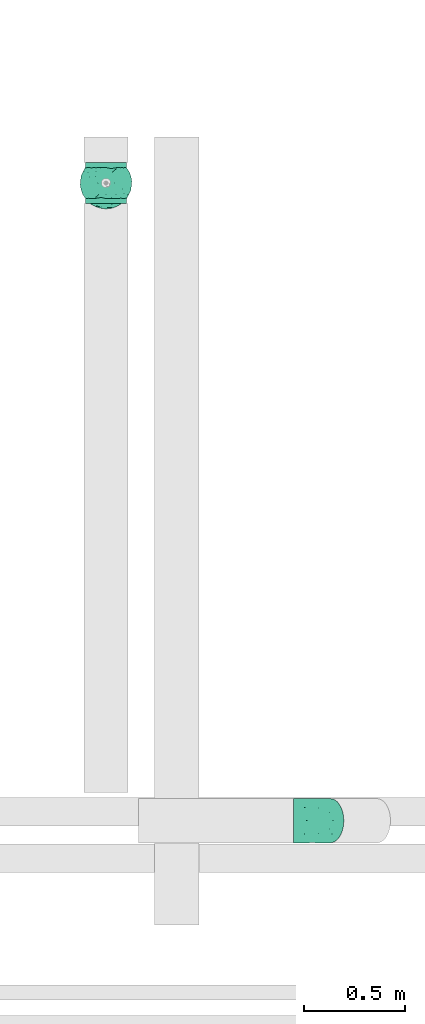
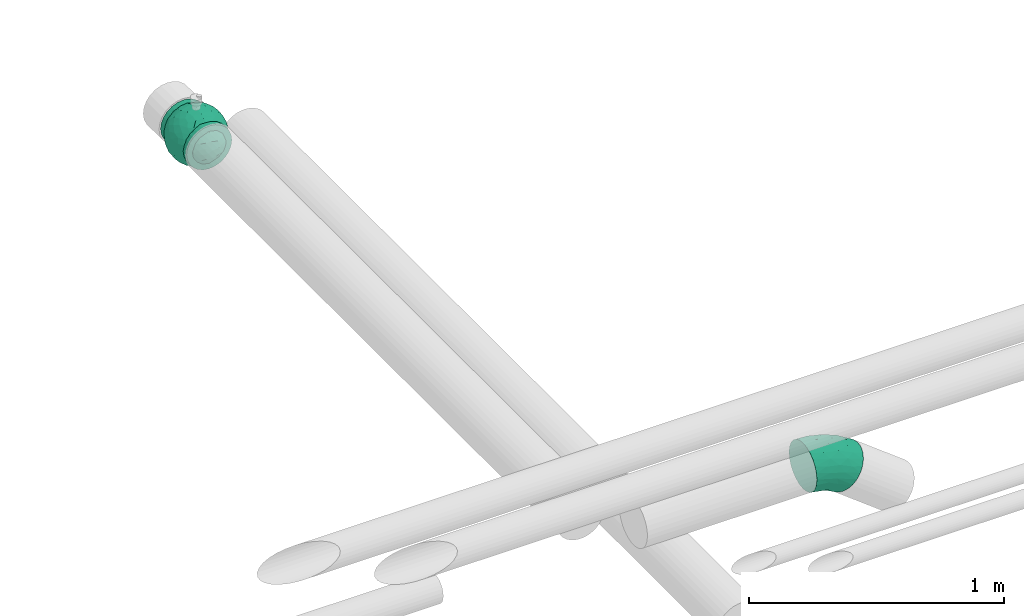
# One storey, part 6 of 6: 2 flow fittings.
"""IFC2X3 building model written with IfcOpenShell, lengths in millimetres."""

from ifc_helpers import new_model, entity, si_unit, converted_unit, derived_unit, direction, frame, origin, place, context, subcontext, project, spatial, faceted_brep, source, transform, mapped, material, material_list, type_object, type_shapes, element, save


model = new_model("IFC2X3")

# Units and contexts
model_context = context("Model", 3, precision=0.01, world=origin(), true_north=direction((6.12303176911189e-17, 1.0)))
body_context = subcontext(model_context, "Body", "Model", "MODEL_VIEW")
ifc_project = project(units=[si_unit("LENGTHUNIT", "METRE", prefix="MILLI"), si_unit("AREAUNIT", "SQUARE_METRE"), si_unit("VOLUMEUNIT", "CUBIC_METRE"), converted_unit("PLANEANGLEUNIT", "DEGREE", entity("IfcRatioMeasure", 0.0174532925199433), si_unit("PLANEANGLEUNIT", "RADIAN"), dimensions=[0, 0, 0, 0, 0, 0, 0]), si_unit("MASSUNIT", "GRAM", prefix="KILO"), derived_unit("MASSDENSITYUNIT", [(si_unit("MASSUNIT", "GRAM", prefix="KILO"), 1), (si_unit("LENGTHUNIT", "METRE"), -3)]), derived_unit("MOMENTOFINERTIAUNIT", [(si_unit("LENGTHUNIT", "METRE"), 4)]), si_unit("TIMEUNIT", "SECOND"), si_unit("FREQUENCYUNIT", "HERTZ"), si_unit("THERMODYNAMICTEMPERATUREUNIT", "DEGREE_CELSIUS"), derived_unit("THERMALTRANSMITTANCEUNIT", [(si_unit("MASSUNIT", "GRAM", prefix="KILO"), 1), (si_unit("THERMODYNAMICTEMPERATUREUNIT", "KELVIN"), -1), (si_unit("TIMEUNIT", "SECOND"), -3)]), derived_unit("VOLUMETRICFLOWRATEUNIT", [(si_unit("LENGTHUNIT", "METRE"), 3), (si_unit("TIMEUNIT", "SECOND"), -1)]), derived_unit("MASSFLOWRATEUNIT", [(si_unit("MASSUNIT", "GRAM", prefix="KILO"), 1), (si_unit("TIMEUNIT", "SECOND"), -1)]), derived_unit("ROTATIONALFREQUENCYUNIT", [(si_unit("TIMEUNIT", "SECOND"), -1)]), si_unit("ELECTRICCURRENTUNIT", "AMPERE"), si_unit("ELECTRICVOLTAGEUNIT", "VOLT"), si_unit("POWERUNIT", "WATT"), si_unit("FORCEUNIT", "NEWTON", prefix="KILO"), si_unit("ILLUMINANCEUNIT", "LUX"), si_unit("LUMINOUSFLUXUNIT", "LUMEN"), si_unit("LUMINOUSINTENSITYUNIT", "CANDELA"), derived_unit("USERDEFINED", [(si_unit("MASSUNIT", "GRAM", prefix="KILO"), -1), (si_unit("LENGTHUNIT", "METRE"), -2), (si_unit("TIMEUNIT", "SECOND"), 3), (si_unit("LUMINOUSFLUXUNIT", "LUMEN"), 1)]), derived_unit("LINEARVELOCITYUNIT", [(si_unit("LENGTHUNIT", "METRE"), 1), (si_unit("TIMEUNIT", "SECOND"), -1)]), si_unit("PRESSUREUNIT", "PASCAL"), derived_unit("USERDEFINED", [(si_unit("LENGTHUNIT", "METRE"), -2), (si_unit("MASSUNIT", "GRAM", prefix="KILO"), 1), (si_unit("TIMEUNIT", "SECOND"), -2)]), derived_unit("LINEARFORCEUNIT", [(si_unit("MASSUNIT", "GRAM", prefix="KILO"), 1), (si_unit("LENGTHUNIT", "METRE"), 1), (si_unit("TIMEUNIT", "SECOND"), -2), (si_unit("LENGTHUNIT", "METRE"), -1)]), derived_unit("PLANARFORCEUNIT", [(si_unit("MASSUNIT", "GRAM", prefix="KILO"), 1), (si_unit("LENGTHUNIT", "METRE"), 1), (si_unit("TIMEUNIT", "SECOND"), -2), (si_unit("LENGTHUNIT", "METRE"), -2)])], contexts=[model_context])

# Site, building, storey
site_placement = place(None, origin())
site = spatial("IfcSite", under=ifc_project, at=site_placement, CompositionType="ELEMENT")
building_placement = place(site_placement, origin())
building = spatial("IfcBuilding", under=site, at=building_placement, CompositionType="ELEMENT")
storey_placement = place(building_placement, origin())
storey = spatial("IfcBuildingStorey", under=building, at=storey_placement, Name="01", CompositionType="ELEMENT", Elevation=0.0)

# Flow fittings
ifc_material_1 = material()
ifc_material_2 = material(Name="ADSK_")
ifc_material_list = material_list([ifc_material_1, ifc_material_2])
pipe_fitting_type_1 = type_object("IfcPipeFittingType", Name="ADSK_2", PredefinedType="NOTDEFINED", material=ifc_material_list)
shared_shape_1 = source(origin(), body_context, "Body", "Brep", [
    faceted_brep([(-102.5, 0.0, -102.5), (-102.5, -26.53, -99.01), (-102.5, -51.25, -88.77), (-102.5, -72.48, -72.48), (-102.5, -88.77, -51.25), (-102.5, -99.01, -26.53), (-102.5, -102.5, 0.0), (-102.5, -99.01, 26.53), (-102.5, -88.77, 51.25), (-102.5, -72.48, 72.48), (-102.5, -51.25, 88.77), (-102.5, -26.53, 99.01), (-102.5, 0.0, 102.5), (-102.5, 26.53, 99.01), (-102.5, 51.25, 88.77), (-102.5, 72.48, 72.48), (-102.5, 88.77, 51.25), (-102.5, 99.01, 26.53), (-102.5, 102.5, 0.0), (-102.5, 99.01, -26.53), (-102.5, 88.77, -51.25), (-102.5, 72.48, -72.48), (-102.5, 51.25, -88.77), (-102.5, 26.53, -99.01), (102.5, 26.53, -99.01), (102.5, 51.25, -88.77), (102.5, 72.48, -72.48), (102.5, 88.77, -51.25), (102.5, 99.01, -26.53), (102.5, 102.5, 0.0), (102.5, 99.01, 26.53), (102.5, 88.77, 51.25), (102.5, 72.48, 72.48), (102.5, 51.25, 88.77), (102.5, 26.53, 99.01), (102.5, 0.0, 102.5), (102.5, -26.53, 99.01), (102.5, -51.25, 88.77), (102.5, -72.48, 72.48), (102.5, -88.77, 51.25), (102.5, -99.01, 26.53), (102.5, -102.5, 0.0), (102.5, -99.01, -26.53), (102.5, -88.77, -51.25), (102.5, -72.48, -72.48), (102.5, -51.25, -88.77), (102.5, -26.53, -99.01), (102.5, 0.0, -102.5), (6.25, -102.5, 0.0), (5.87, -102.48, 2.14), (4.79, -102.42, 4.02), (3.13, -102.36, 5.41), (1.08, -102.32, 6.16), (-5.87, -102.48, 2.14), (-4.79, -102.42, 4.02), (-6.25, -102.5, 0.0), (-3.13, -102.36, 5.41), (-1.09, -102.32, 6.15), (1.08, -102.32, -6.16), (5.87, -102.48, -2.14), (4.79, -102.42, -4.02), (3.13, -102.36, -5.41), (-1.09, -102.32, -6.15), (-3.13, -102.36, -5.41), (-4.79, -102.42, -4.02), (-5.87, -102.48, -2.14), (0.0, -107.5, -6.25), (1.62, -107.5, -6.04), (3.13, -107.5, -5.41), (4.42, -107.5, -4.42), (5.41, -107.5, -3.13), (6.04, -107.5, -1.62), (6.25, -107.5, 0.0), (6.04, -107.5, 1.62), (5.41, -107.5, 3.12), (4.42, -107.5, 4.42), (3.13, -107.5, 5.41), (1.62, -107.5, 6.04), (0.0, -107.5, 6.25), (-1.62, -107.5, 6.04), (-3.12, -107.5, 5.41), (-4.42, -107.5, 4.42), (-5.41, -107.5, 3.12), (-6.04, -107.5, 1.62), (-6.25, -107.5, 0.0), (-6.04, -107.5, -1.62), (-5.41, -107.5, -3.13), (-4.42, -107.5, -4.42), (-3.12, -107.5, -5.41), (-1.62, -107.5, -6.04)], [[[0, 1, 2, 3, 4, 5, 6, 7, 8, 9, 10, 11, 12, 13, 14, 15, 16, 17, 18, 19, 20, 21, 22, 23]], [[24, 25, 26, 27, 28, 29, 30, 31, 32, 33, 34, 35, 36, 37, 38, 39, 40, 41, 42, 43, 44, 45, 46, 47]], [[48, 41, 49]], [[50, 49, 41]], [[41, 51, 50]], [[8, 7, 40, 39]], [[41, 52, 51]], [[52, 41, 40]], [[7, 52, 40]], [[39, 38, 9, 8]], [[53, 54, 6]], [[6, 55, 53]], [[54, 56, 6]], [[57, 7, 6]], [[52, 7, 57]], [[57, 6, 56]], [[38, 37, 10, 9]], [[12, 11, 36, 35]], [[11, 10, 37, 36]], [[13, 12, 35, 34]], [[31, 30, 17, 16]], [[15, 14, 33, 32]], [[16, 15, 32, 31]], [[34, 33, 14, 13]], [[18, 17, 30, 29]], [[20, 19, 28, 27]], [[19, 18, 29, 28]], [[21, 20, 27, 26]], [[47, 46, 1, 0]], [[23, 22, 25, 24]], [[0, 23, 24, 47]], [[26, 25, 22, 21]], [[2, 1, 46, 45]], [[45, 44, 3, 2]], [[5, 4, 43, 42]], [[58, 5, 42]], [[43, 4, 3, 44]], [[42, 41, 58]], [[41, 48, 59]], [[60, 61, 41]], [[59, 60, 41]], [[41, 61, 58]], [[58, 62, 5]], [[62, 6, 5]], [[63, 64, 6]], [[65, 55, 6]], [[65, 6, 64]], [[63, 6, 62]], [[66, 67, 68, 69, 70, 71, 72, 73, 74, 75, 76, 77, 78, 79, 80, 81, 82, 83, 84, 85, 86, 87, 88, 89]], [[84, 83, 55]], [[81, 80, 54]], [[82, 81, 54]], [[83, 82, 53]], [[55, 83, 53]], [[53, 82, 54]], [[56, 79, 57]], [[56, 54, 80]], [[57, 79, 78]], [[56, 80, 79]], [[77, 76, 51]], [[78, 77, 52]], [[74, 73, 49]], [[75, 74, 50]], [[76, 75, 50]], [[76, 50, 51]], [[51, 52, 77]], [[73, 48, 49]], [[49, 50, 74]], [[73, 72, 48]], [[78, 52, 57]], [[72, 71, 48]], [[69, 68, 60]], [[70, 69, 60]], [[71, 70, 59]], [[48, 71, 59]], [[59, 70, 60]], [[61, 67, 58]], [[61, 60, 68]], [[58, 67, 66]], [[61, 68, 67]], [[89, 88, 63]], [[66, 89, 62]], [[86, 85, 65]], [[87, 86, 64]], [[88, 87, 64]], [[88, 64, 63]], [[63, 62, 89]], [[85, 55, 65]], [[65, 64, 86]], [[85, 84, 55]], [[66, 62, 58]]]),
    faceted_brep([(103.66, -75.31, 0.0), (112.67, -37.71, -47.95), (119.68, -38.65, -24.46), (100.39, 25.74, -75.33), (105.47, -0.45, -72.74), (87.71, 0.0, -93.4), (121.85, -39.59, 0.0), (112.75, -57.45, 0.0), (117.35, 10.45, -50.35), (111.96, 45.77, -42.26), (67.62, 97.03, -49.29), (83.92, 80.91, -53.17), (73.94, 63.55, -83.12), (115.42, -13.68, -53.92), (123.96, -14.86, -28.8), (96.32, -72.86, -42.79), (89.48, -89.48, 0.0), (75.31, -103.66, 0.0), (89.48, 89.48, 0.0), (103.01, 69.91, -30.31), (-29.36, -93.22, -82.85), (-59.51, -102.32, -49.05), (-52.27, -74.51, -90.18), (125.29, 12.16, -23.88), (128.13, 0.0, 0.0), (112.75, 57.45, 0.0), (119.72, 39.01, -23.71), (77.61, 29.8, -97.5), (-119.71, 38.94, -23.86), (-124.41, 0.58, -30.62), (-121.85, 39.59, 0.0), (89.61, -41.49, -81.64), (4.38, 117.84, -50.1), (32.72, 118.23, -36.99), (11.16, 104.77, -72.9), (-112.75, 57.45, 0.0), (-103.66, 75.31, 0.0), (50.37, 71.59, -93.56), (35.32, 103.01, -67.51), (50.37, -71.59, -93.56), (67.49, -50.53, -96.47), (82.04, -68.31, -70.84), (-75.31, -103.66, 0.0), (-89.48, -89.48, 0.0), (-89.39, -85.39, -33.7), (-35.73, -2.64, -123.01), (-75.31, 0.0, -103.66), (-54.88, 35.9, -110.07), (-120.43, -29.42, -32.37), (-114.01, -8.85, -57.79), (-108.35, -40.08, -55.41), (-52.27, 74.51, -90.18), (-73.84, 91.26, -51.34), (-46.3, 104.5, -57.91), (-32.09, -62.84, -106.95), (-57.65, -36.81, -108.34), (-33.38, -37.89, -117.75), (-76.97, -84.04, -58.56), (-73.72, -58.24, -87.12), (-18.02, 55.57, -114.03), (-121.85, -39.59, 0.0), (-29.91, 89.89, -86.26), (-76.68, 66.43, -78.25), (-102.63, 37.68, -66.81), (-96.32, 72.91, -42.68), (-88.67, 39.81, -83.47), (32.42, -10.97, -123.47), (54.26, -1.64, -116.06), (53.15, -26.46, -113.54), (-112.96, 38.28, -46.81), (50.79, 23.01, -115.36), (55.04, 48.17, -105.19), (20.5, -110.73, -61.11), (0.77, -121.6, -40.35), (0.05, -102.71, -76.6), (-31.11, -113.42, -50.84), (-86.58, -32.21, -88.78), (-89.48, 89.48, 0.0), (-75.31, 103.66, 0.0), (-107.5, 16.33, -67.78), (-93.17, 17.31, -86.23), (75.07, -27.21, -100.21), (-93.37, -62.04, -62.04), (-97.29, -5.48, -83.19), (-55.39, 111.83, -29.03), (-57.45, 112.75, 0.0), (-39.59, 121.85, 0.0), (-35.64, 118.01, -34.93), (-20.19, 109.53, -63.34), (39.59, 121.85, 0.0), (51.67, 110.16, -40.12), (-16.88, 120.75, -39.38), (-0.57, 125.47, -25.96), (17.69, 62.69, -110.33), (-0.59, 88.7, -92.46), (26.41, 85.02, -92.15), (-24.43, 26.45, -122.96), (8.05, 0.42, -127.87), (13.92, -30.45, -123.67), (-13.74, -21.43, -125.57), (45.36, -49.83, -108.98), (-3.24, -78.6, -101.13), (55.42, -90.6, -71.66), (-19.8, -124.99, 0.0), (5.84, 33.69, -123.48), (72.43, -91.39, -53.08), (55.5, -110.31, -34.18), (57.45, -112.75, 0.0), (39.59, -121.85, 0.0), (19.8, -124.99, 0.0), (0.0, -128.13, 0.0), (23.43, -89.6, -88.53), (34.27, -118.7, -33.96), (41.3, -104.28, -61.93), (-39.59, -121.85, 0.0), (-57.45, -112.75, 0.0), (21.97, -58.98, -111.6), (31.58, 41.12, -117.16), (19.8, 124.99, 0.0), (57.45, 112.75, 0.0), (93.95, 56.43, -66.37), (-74.35, -100.36, -28.55), (-103.1, -68.8, -32.46), (-112.75, -57.45, 0.0), (-103.66, -75.31, 0.0), (-128.12, 0.0, 0.0), (-10.48, -49.37, -117.77), (121.85, 39.59, 0.0), (103.66, 75.31, 0.0), (75.31, 103.66, 0.0), (-19.8, 124.99, 0.0), (0.0, 128.12, 0.0), (-112.67, -37.71, 47.95), (-119.68, -38.65, 24.46), (-100.39, 25.74, 75.33), (-105.47, -0.45, 72.74), (-87.71, 0.0, 93.4), (-117.35, 10.45, 50.35), (-111.96, 45.77, 42.26), (-67.62, 97.03, 49.29), (-83.92, 80.91, 53.17), (-73.94, 63.55, 83.12), (-115.42, -13.68, 53.92), (-123.96, -14.86, 28.8), (-96.32, -72.86, 42.79), (-103.01, 69.91, 30.31), (29.36, -93.22, 82.85), (59.51, -102.32, 49.05), (52.27, -74.51, 90.18), (-125.29, 12.16, 23.88), (-119.72, 39.01, 23.71), (-77.61, 29.8, 97.5), (119.71, 38.94, 23.86), (124.41, 0.58, 30.62), (-89.61, -41.49, 81.64), (-4.38, 117.84, 50.1), (-32.72, 118.23, 36.99), (-11.16, 104.77, 72.9), (-50.37, 71.59, 93.56), (-35.32, 103.01, 67.51), (-50.37, -71.59, 93.56), (-67.49, -50.53, 96.47), (-82.04, -68.31, 70.84), (89.39, -85.39, 33.7), (35.73, -2.64, 123.01), (75.31, 0.0, 103.66), (54.88, 35.9, 110.07), (120.43, -29.42, 32.37), (114.01, -8.85, 57.79), (108.35, -40.08, 55.41), (52.27, 74.51, 90.18), (73.84, 91.26, 51.34), (46.3, 104.5, 57.91), (32.09, -62.84, 106.95), (57.65, -36.81, 108.34), (33.38, -37.89, 117.75), (76.97, -84.04, 58.56), (73.72, -58.24, 87.12), (18.02, 55.57, 114.03), (29.91, 89.89, 86.26), (76.68, 66.43, 78.25), (102.63, 37.68, 66.81), (96.32, 72.91, 42.68), (88.67, 39.81, 83.47), (-32.42, -10.97, 123.47), (-54.26, -1.64, 116.06), (-53.15, -26.46, 113.54), (112.96, 38.28, 46.81), (-50.79, 23.01, 115.36), (-55.04, 48.17, 105.19), (-20.5, -110.73, 61.11), (-0.77, -121.6, 40.35), (-0.05, -102.71, 76.6), (31.11, -113.42, 50.84), (86.58, -32.21, 88.78), (107.5, 16.33, 67.78), (93.17, 17.31, 86.23), (-75.07, -27.21, 100.21), (93.37, -62.04, 62.04), (103.1, -68.8, 32.46), (97.29, -5.48, 83.19), (55.39, 111.83, 29.03), (35.64, 118.01, 34.93), (20.19, 109.53, 63.34), (-51.67, 110.16, 40.12), (16.88, 120.75, 39.38), (0.57, 125.47, 25.96), (-17.69, 62.69, 110.33), (0.59, 88.7, 92.46), (-26.41, 85.02, 92.15), (24.43, 26.45, 122.96), (-8.05, 0.42, 127.87), (-13.92, -30.45, 123.67), (13.74, -21.43, 125.57), (-45.36, -49.83, 108.98), (3.24, -78.6, 101.13), (-55.42, -90.6, 71.66), (-5.84, 33.69, 123.48), (-72.43, -91.39, 53.08), (-55.5, -110.31, 34.18), (-23.43, -89.6, 88.53), (-34.27, -118.7, 33.96), (-41.3, -104.28, 61.93), (-21.97, -58.98, 111.6), (-31.58, 41.12, 117.16), (-93.95, 56.43, 66.37), (74.35, -100.36, 28.55), (10.48, -49.37, 117.77)], [[[0, 1, 2]], [[3, 4, 5]], [[2, 6, 7, 0]], [[8, 3, 9]], [[10, 11, 12]], [[13, 14, 2]], [[15, 0, 16, 17]], [[18, 19, 11]], [[20, 21, 22]], [[23, 24, 14]], [[25, 26, 9]], [[3, 5, 27]], [[28, 29, 30]], [[15, 31, 1]], [[32, 33, 34]], [[28, 30, 35, 36]], [[10, 37, 38]], [[39, 40, 41]], [[42, 43, 44]], [[45, 46, 47]], [[48, 49, 50]], [[51, 52, 53]], [[54, 55, 56]], [[22, 57, 58]], [[59, 47, 51]], [[60, 29, 48]], [[6, 14, 24]], [[53, 61, 51]], [[48, 29, 49]], [[51, 62, 52]], [[63, 64, 65]], [[66, 67, 68]], [[28, 36, 69]], [[27, 70, 71]], [[72, 73, 74]], [[73, 75, 74]], [[22, 54, 20]], [[76, 46, 55]], [[64, 36, 77, 78]], [[79, 63, 80]], [[81, 31, 40]], [[47, 46, 65]], [[57, 44, 82]], [[76, 83, 46]], [[52, 64, 78]], [[83, 79, 80]], [[62, 64, 52]], [[65, 62, 47]], [[84, 85, 86]], [[84, 52, 85]], [[87, 88, 53]], [[89, 90, 33]], [[91, 92, 32]], [[93, 59, 94]], [[61, 88, 94]], [[87, 91, 88]], [[37, 93, 95]], [[51, 61, 59]], [[59, 96, 47]], [[97, 98, 99]], [[55, 46, 45]], [[68, 100, 98]], [[20, 101, 74]], [[39, 41, 102]], [[75, 73, 103]], [[94, 95, 93]], [[59, 104, 96]], [[45, 99, 56]], [[55, 58, 76]], [[105, 15, 17]], [[31, 5, 4]], [[106, 107, 108]], [[106, 105, 107]], [[109, 110, 73]], [[111, 74, 101]], [[112, 108, 109]], [[73, 110, 103]], [[112, 72, 113]], [[103, 114, 75]], [[21, 75, 114]], [[20, 74, 75]], [[21, 114, 115]], [[58, 57, 82]], [[41, 31, 15]], [[31, 41, 40]], [[39, 111, 116]], [[68, 98, 66]], [[93, 104, 59]], [[70, 117, 71]], [[32, 118, 33]], [[119, 90, 89]], [[90, 10, 38]], [[12, 11, 120]], [[58, 55, 22]], [[76, 82, 50]], [[57, 22, 21]], [[82, 76, 58]], [[21, 115, 121]], [[121, 44, 57]], [[122, 123, 48]], [[122, 43, 124]], [[50, 82, 122]], [[123, 122, 124]], [[50, 49, 83]], [[43, 122, 44]], [[82, 44, 122]], [[50, 122, 48]], [[29, 60, 125]], [[30, 29, 125]], [[79, 29, 69]], [[48, 123, 60]], [[117, 37, 71]], [[117, 97, 104]], [[117, 104, 93]], [[96, 97, 45]], [[97, 96, 104]], [[47, 96, 45]], [[52, 78, 85]], [[21, 20, 75]], [[55, 54, 22]], [[116, 101, 126]], [[111, 113, 72]], [[98, 116, 126]], [[40, 100, 68]], [[116, 111, 101]], [[102, 111, 39]], [[99, 98, 126]], [[98, 97, 66]], [[56, 99, 126]], [[97, 99, 45]], [[56, 126, 54]], [[45, 56, 55]], [[126, 101, 54]], [[20, 54, 101]], [[97, 70, 66]], [[67, 66, 70]], [[27, 67, 70]], [[81, 67, 5]], [[50, 83, 76]], [[83, 49, 79]], [[29, 79, 49]], [[63, 79, 69]], [[65, 46, 80]], [[46, 83, 80]], [[121, 115, 42]], [[6, 2, 14]], [[23, 14, 8]], [[26, 8, 9]], [[127, 24, 23]], [[37, 117, 93]], [[97, 117, 70]], [[37, 12, 71]], [[27, 5, 67]], [[12, 27, 71]], [[3, 27, 120]], [[10, 12, 37]], [[27, 12, 120]], [[9, 3, 120]], [[4, 3, 8]], [[19, 18, 128]], [[19, 128, 9]], [[10, 129, 11]], [[11, 129, 18]], [[127, 26, 25]], [[9, 120, 19]], [[11, 19, 120]], [[8, 13, 4]], [[31, 4, 1]], [[14, 13, 8]], [[1, 4, 13]], [[105, 17, 107]], [[112, 106, 108]], [[106, 113, 102]], [[92, 118, 32]], [[64, 63, 69]], [[80, 63, 65]], [[1, 0, 15]], [[2, 1, 13]], [[69, 36, 64]], [[29, 28, 69]], [[47, 62, 51]], [[64, 62, 65]], [[88, 61, 53]], [[59, 61, 94]], [[84, 87, 53]], [[88, 32, 34]], [[86, 130, 87]], [[88, 91, 32]], [[87, 130, 91]], [[92, 130, 131]], [[130, 92, 91]], [[118, 92, 131]], [[106, 102, 105]], [[111, 102, 113]], [[73, 112, 109]], [[106, 112, 113]], [[73, 72, 112]], [[111, 72, 74]], [[15, 105, 41]], [[41, 105, 102]], [[100, 40, 39]], [[81, 40, 68]], [[39, 116, 100]], [[98, 100, 116]], [[67, 81, 68]], [[5, 31, 81]], [[95, 34, 38]], [[88, 34, 94]], [[33, 90, 38]], [[90, 119, 10]], [[33, 38, 34]], [[129, 10, 119]], [[89, 33, 118]], [[34, 95, 94]], [[37, 95, 38]], [[87, 84, 86]], [[52, 84, 53]], [[44, 121, 42]], [[21, 121, 57]], [[9, 128, 25]], [[127, 23, 26]], [[8, 26, 23]], [[124, 132, 133]], [[134, 135, 136]], [[133, 60, 123, 124]], [[137, 134, 138]], [[139, 140, 141]], [[142, 143, 133]], [[144, 124, 43, 42]], [[77, 145, 140]], [[146, 147, 148]], [[149, 125, 143]], [[35, 150, 138]], [[134, 136, 151]], [[152, 153, 127]], [[144, 154, 132]], [[155, 156, 157]], [[152, 127, 25, 128]], [[139, 158, 159]], [[160, 161, 162]], [[17, 16, 163]], [[164, 165, 166]], [[167, 168, 169]], [[170, 171, 172]], [[173, 174, 175]], [[148, 176, 177]], [[178, 166, 170]], [[6, 153, 167]], [[60, 143, 125]], [[172, 179, 170]], [[167, 153, 168]], [[170, 180, 171]], [[181, 182, 183]], [[184, 185, 186]], [[152, 128, 187]], [[151, 188, 189]], [[190, 191, 192]], [[191, 193, 192]], [[148, 173, 146]], [[194, 165, 174]], [[182, 128, 18, 129]], [[195, 181, 196]], [[197, 154, 161]], [[166, 165, 183]], [[169, 198, 199]], [[194, 200, 165]], [[171, 182, 129]], [[200, 195, 196]], [[180, 182, 171]], [[183, 180, 166]], [[201, 119, 89]], [[201, 171, 119]], [[202, 203, 172]], [[86, 204, 156]], [[205, 206, 155]], [[207, 178, 208]], [[179, 203, 208]], [[202, 205, 203]], [[158, 207, 209]], [[170, 179, 178]], [[178, 210, 166]], [[211, 212, 213]], [[174, 165, 164]], [[186, 214, 212]], [[146, 215, 192]], [[160, 162, 216]], [[193, 191, 109]], [[208, 209, 207]], [[178, 217, 210]], [[164, 213, 175]], [[174, 177, 194]], [[218, 144, 42]], [[154, 136, 135]], [[219, 115, 114]], [[219, 218, 115]], [[103, 110, 191]], [[220, 192, 215]], [[221, 114, 103]], [[191, 110, 109]], [[221, 190, 222]], [[109, 108, 193]], [[147, 193, 108]], [[146, 192, 193]], [[147, 108, 107]], [[177, 176, 198]], [[162, 154, 144]], [[154, 162, 161]], [[160, 220, 223]], [[186, 212, 184]], [[207, 217, 178]], [[188, 224, 189]], [[155, 130, 156]], [[85, 204, 86]], [[204, 139, 159]], [[141, 140, 225]], [[177, 174, 148]], [[194, 198, 169]], [[176, 148, 147]], [[198, 194, 177]], [[147, 107, 226]], [[226, 163, 176]], [[199, 7, 167]], [[0, 199, 16]], [[163, 198, 176]], [[7, 199, 0]], [[169, 168, 200]], [[16, 199, 163]], [[198, 163, 199]], [[169, 199, 167]], [[153, 6, 24]], [[127, 153, 24]], [[195, 153, 187]], [[167, 7, 6]], [[224, 158, 189]], [[224, 211, 217]], [[224, 217, 207]], [[210, 211, 164]], [[211, 210, 217]], [[166, 210, 164]], [[171, 129, 119]], [[147, 146, 193]], [[174, 173, 148]], [[223, 215, 227]], [[220, 222, 190]], [[212, 223, 227]], [[161, 214, 186]], [[223, 220, 215]], [[216, 220, 160]], [[213, 212, 227]], [[212, 211, 184]], [[175, 213, 227]], [[211, 213, 164]], [[175, 227, 173]], [[164, 175, 174]], [[227, 215, 173]], [[146, 173, 215]], [[211, 188, 184]], [[185, 184, 188]], [[151, 185, 188]], [[197, 185, 136]], [[169, 200, 194]], [[200, 168, 195]], [[153, 195, 168]], [[181, 195, 187]], [[183, 165, 196]], [[165, 200, 196]], [[226, 107, 17]], [[60, 133, 143]], [[149, 143, 137]], [[150, 137, 138]], [[30, 125, 149]], [[158, 224, 207]], [[211, 224, 188]], [[158, 141, 189]], [[151, 136, 185]], [[141, 151, 189]], [[134, 151, 225]], [[139, 141, 158]], [[151, 141, 225]], [[138, 134, 225]], [[135, 134, 137]], [[145, 77, 36]], [[145, 36, 138]], [[139, 78, 140]], [[140, 78, 77]], [[30, 150, 35]], [[138, 225, 145]], [[140, 145, 225]], [[137, 142, 135]], [[154, 135, 132]], [[143, 142, 137]], [[132, 135, 142]], [[218, 42, 115]], [[221, 219, 114]], [[219, 222, 216]], [[206, 130, 155]], [[182, 181, 187]], [[196, 181, 183]], [[132, 124, 144]], [[133, 132, 142]], [[187, 128, 182]], [[153, 152, 187]], [[166, 180, 170]], [[182, 180, 183]], [[203, 179, 172]], [[178, 179, 208]], [[201, 202, 172]], [[203, 155, 157]], [[89, 118, 202]], [[203, 205, 155]], [[202, 118, 205]], [[206, 118, 131]], [[118, 206, 205]], [[130, 206, 131]], [[219, 216, 218]], [[220, 216, 222]], [[191, 221, 103]], [[219, 221, 222]], [[191, 190, 221]], [[220, 190, 192]], [[144, 218, 162]], [[162, 218, 216]], [[214, 161, 160]], [[197, 161, 186]], [[160, 223, 214]], [[212, 214, 223]], [[185, 197, 186]], [[136, 154, 197]], [[209, 157, 159]], [[203, 157, 208]], [[156, 204, 159]], [[204, 85, 139]], [[156, 159, 157]], [[78, 139, 85]], [[86, 156, 130]], [[157, 209, 208]], [[158, 209, 159]], [[202, 201, 89]], [[171, 201, 172]], [[163, 226, 17]], [[147, 226, 176]], [[138, 36, 35]], [[30, 149, 150]], [[137, 150, 149]]]),
])
type_shapes(pipe_fitting_type_1, [shared_shape_1])
flow_fitting_1_placement = place(storey_placement, frame((31080.0, 10422.33, 31000.0), z_axis=(-1.0, 0.0, -1.0136969447085e-07), x_axis=(0.0, 1.0, 0.0)))
element("IfcFlowFitting", 1, at=flow_fitting_1_placement, inside=storey, type_object=pipe_fitting_type_1, material=ifc_material_list, Name="ADSK_2", ObjectType="ADSK_2", context=body_context, shape_type="MappedRepresentation", body=[
    mapped(shared_shape_1, transform((0.0, 0.0, 0.0), scale=1.0)),
])
pipe_fitting_type_2 = type_object("IfcPipeFittingType", Name="ADSK_2", PredefinedType="NOTDEFINED", material=ifc_material_1)
shared_shape_2 = source(origin(), body_context, "Body", "Brep", [
    faceted_brep([(-101.57, 54.75, -94.83), (-101.57, 28.34, -105.77), (-101.57, 0.0, -109.5), (-101.57, -28.34, -105.77), (-101.57, -54.75, -94.83), (-101.57, -77.43, -77.43), (-101.57, -94.83, -54.75), (-101.57, -105.77, -28.34), (-101.57, -109.5, 0.0), (-101.57, -105.77, 28.34), (-101.57, -94.83, 54.75), (-101.57, -77.43, 77.43), (-101.57, -54.75, 94.83), (-101.57, -28.34, 105.77), (-101.57, 0.0, 109.5), (-101.57, 28.34, 105.77), (-101.57, 54.75, 94.83), (-101.57, 77.43, 77.43), (-101.57, 94.83, 54.75), (-101.57, 105.77, 28.34), (-101.57, 109.5, 0.0), (-101.57, 105.77, -28.34), (-101.57, 94.83, -54.75), (-101.57, 77.43, -77.43), (80.68, 61.7, -109.5), (63.46, 84.21, -105.77), (47.42, 105.19, -94.83), (33.64, 123.2, -77.43), (23.07, 137.03, -54.75), (16.43, 145.72, -28.34), (14.16, 148.68, 0.0), (16.43, 145.72, 28.34), (23.07, 137.03, 54.75), (33.64, 123.2, 77.43), (47.42, 105.19, 94.83), (63.46, 84.21, 105.77), (80.68, 61.7, 109.5), (97.89, 39.19, 105.77), (113.94, 18.21, 94.83), (127.71, 0.2, 77.43), (138.29, -13.63, 54.75), (144.93, -22.32, 28.34), (147.2, -25.28, 0.0), (144.93, -22.32, -28.34), (138.29, -13.63, -54.75), (127.71, 0.2, -77.43), (113.94, 18.21, -94.83), (97.89, 39.19, -105.77), (-35.02, -104.06, 0.0), (-5.16, -93.09, 31.93), (66.29, 0.78, 100.67), (-22.04, -59.61, 85.59), (-53.13, -39.65, 100.67), (8.95, -26.42, 100.0), (-45.21, -83.64, 65.49), (-28.61, -7.73, 108.29), (-9.11, 26.91, 108.88), (23.12, -68.3, 64.02), (29.75, -87.87, 0.0), (91.03, -61.38, 0.0), (61.21, -73.96, 18.93), (-36.07, 48.51, 101.88), (-26.15, 77.24, 88.25), (74.75, -61.21, 39.96), (86.73, -38.97, 65.49), (-40.59, 94.57, 68.14), (-37.56, 110.94, 43.72), (-39.78, 117.5, 21.7), (58.51, -31.57, 85.68), (13.83, 55.63, 105.38), (39.17, 17.17, 108.34), (-60.44, 113.99, 0.0), (-21.24, 127.26, 0.0), (5.7, 73.42, 97.77), (-44.78, 35.79, -105.38), (-49.13, 54.86, -97.77), (-0.82, 60.44, -101.88), (-5.16, -93.09, -31.93), (-26.15, 77.24, -88.25), (-39.78, 117.5, -21.7), (-37.56, 110.94, -43.72), (8.95, -26.42, -100.0), (53.72, -33.96, -85.59), (-27.3, -60.62, -85.68), (-25.21, 99.78, -68.14), (-9.11, 26.91, -108.88), (27.42, 11.24, -108.29), (-41.54, -10.15, -108.34), (-45.21, -83.64, -65.49), (-53.13, -39.65, -100.67), (23.12, -68.3, -64.02), (61.21, -73.96, -18.93), (74.75, -61.21, -39.96), (66.29, 0.78, -100.67), (86.73, -38.97, -65.49)], [[[0, 1, 2, 3, 4, 5, 6, 7, 8, 9, 10, 11, 12, 13, 14, 15, 16, 17, 18, 19, 20, 21, 22, 23]], [[24, 25, 26, 27, 28, 29, 30, 31, 32, 33, 34, 35, 36, 37, 38, 39, 40, 41, 42, 43, 44, 45, 46, 47]], [[48, 49, 9]], [[48, 9, 8]], [[38, 37, 50]], [[12, 11, 51]], [[52, 51, 53]], [[54, 11, 10]], [[14, 13, 55]], [[13, 12, 52]], [[14, 55, 56]], [[49, 57, 54]], [[49, 54, 10]], [[58, 59, 60]], [[16, 15, 61]], [[17, 16, 62]], [[63, 40, 64]], [[18, 65, 66]], [[15, 14, 56]], [[34, 33, 62]], [[54, 51, 11]], [[66, 67, 19]], [[40, 39, 64]], [[20, 19, 67]], [[19, 18, 66]], [[57, 64, 68]], [[62, 16, 61]], [[49, 58, 60]], [[48, 58, 49]], [[35, 69, 36]], [[38, 68, 39]], [[56, 70, 36]], [[68, 38, 50]], [[56, 55, 70]], [[63, 60, 41]], [[70, 37, 36]], [[41, 60, 59]], [[49, 63, 57]], [[17, 62, 65]], [[51, 68, 53]], [[33, 65, 62]], [[59, 42, 41]], [[49, 60, 63]], [[57, 68, 51]], [[18, 17, 65]], [[71, 67, 72]], [[10, 9, 49]], [[72, 67, 30]], [[53, 50, 70]], [[67, 31, 30]], [[15, 56, 61]], [[66, 65, 32]], [[67, 71, 20]], [[32, 65, 33]], [[31, 67, 66]], [[69, 35, 73]], [[69, 73, 61]], [[32, 31, 66]], [[69, 61, 56]], [[40, 63, 41]], [[53, 70, 55]], [[52, 55, 13]], [[51, 54, 57]], [[68, 64, 39]], [[63, 64, 57]], [[51, 52, 12]], [[55, 52, 53]], [[70, 50, 37]], [[68, 50, 53]], [[36, 69, 56]], [[73, 35, 34]], [[34, 62, 73]], [[62, 61, 73]], [[74, 1, 75]], [[75, 76, 74]], [[6, 77, 7]], [[23, 78, 0]], [[71, 79, 20]], [[79, 21, 20]], [[80, 22, 21]], [[81, 82, 83]], [[84, 23, 22]], [[85, 86, 87]], [[26, 25, 76]], [[2, 1, 74]], [[7, 77, 48]], [[85, 87, 2]], [[48, 8, 7]], [[83, 88, 5]], [[6, 88, 77]], [[81, 87, 86]], [[89, 4, 3]], [[90, 88, 83]], [[6, 5, 88]], [[5, 4, 83]], [[2, 87, 3]], [[28, 27, 84]], [[43, 91, 92]], [[93, 86, 47]], [[79, 71, 72]], [[77, 91, 58]], [[30, 29, 79]], [[94, 82, 45]], [[80, 29, 28]], [[44, 43, 92]], [[46, 45, 82]], [[80, 28, 84]], [[26, 76, 78]], [[94, 92, 90]], [[85, 25, 24]], [[90, 92, 77]], [[80, 84, 22]], [[26, 78, 27]], [[81, 89, 87]], [[85, 24, 86]], [[82, 81, 93]], [[90, 83, 82]], [[24, 47, 86]], [[77, 92, 91]], [[44, 94, 45]], [[47, 46, 93]], [[59, 58, 91]], [[74, 76, 85]], [[42, 59, 43]], [[21, 79, 80]], [[25, 85, 76]], [[48, 77, 58]], [[83, 4, 89]], [[91, 43, 59]], [[27, 78, 84]], [[79, 29, 80]], [[23, 84, 78]], [[79, 72, 30]], [[77, 88, 90]], [[92, 94, 44]], [[82, 94, 90]], [[87, 89, 3]], [[83, 89, 81]], [[82, 93, 46]], [[86, 93, 81]], [[2, 74, 85]], [[75, 1, 0]], [[0, 78, 75]], [[78, 76, 75]]]),
])
type_shapes(pipe_fitting_type_2, [shared_shape_2])
flow_fitting_2_placement = place(storey_placement, frame((32110.0, 7266.2, 30999.99), z_axis=(0.0, 1.0, 0.0), x_axis=(1.0, 0.0, 0.0)))
element("IfcFlowFitting", 2, at=flow_fitting_2_placement, inside=storey, type_object=pipe_fitting_type_2, material=ifc_material_1, Name="ADSK_2", ObjectType="ADSK_2", context=body_context, shape_type="MappedRepresentation", body=[
    mapped(shared_shape_2, transform((0.0, 0.0, 0.0), scale=1.0)),
])

save(model, "model.ifc")
